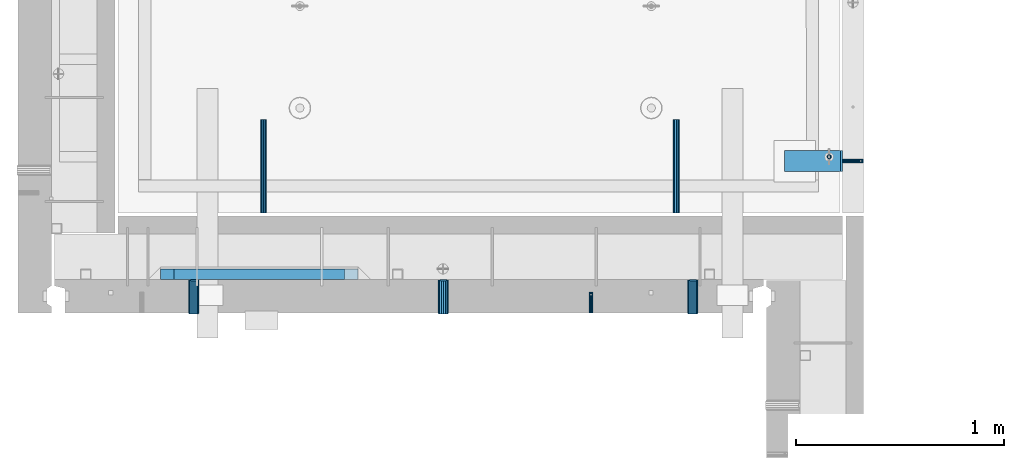
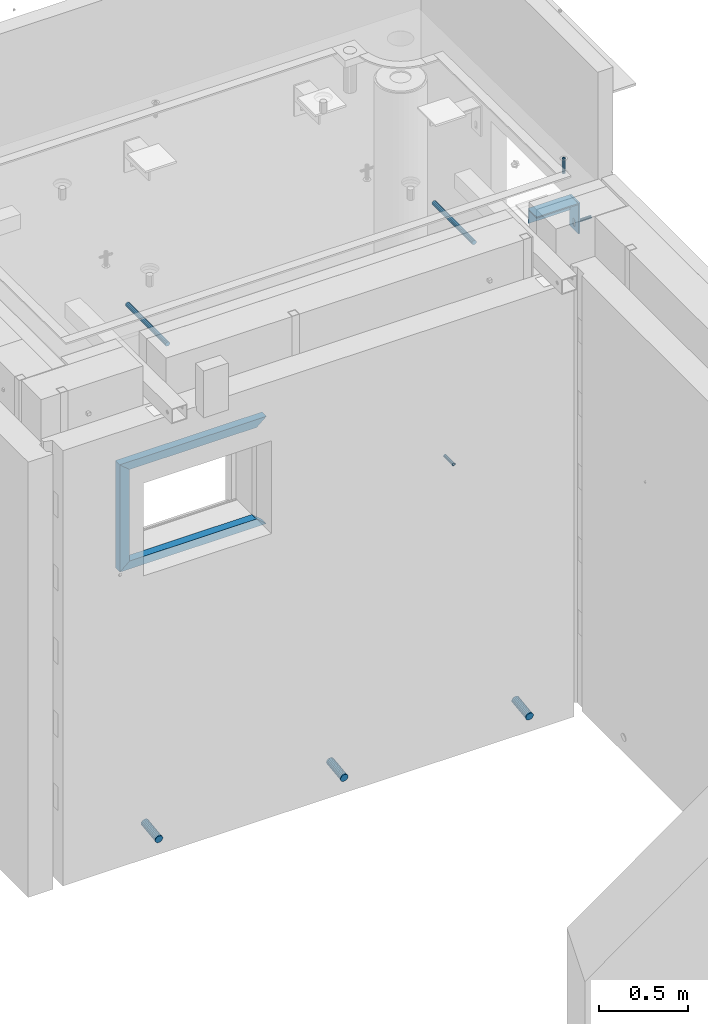
# One storey, part 113 of 264: 13 beams, 13 elements without a shape of their own.
"""IFC2X3 building model written with IfcOpenShell, lengths in millimetres."""

from ifc_helpers import new_model, si_unit, frame, origin_with_axes, place, context, subcontext, project, spatial, faceted_brep, material, type_object, element, aggregate, save


model = new_model("IFC2X3")

# Units and contexts
model_context = context("Model", 3, precision=1e-05, world=origin_with_axes())
body_context = subcontext(model_context, "Body", "Model", "MODEL_VIEW")
ifc_project = project(units=[si_unit("LENGTHUNIT", "METRE", prefix="MILLI"), si_unit("AREAUNIT", "SQUARE_METRE"), si_unit("VOLUMEUNIT", "CUBIC_METRE"), si_unit("MASSUNIT", "GRAM", prefix="KILO"), si_unit("TIMEUNIT", "SECOND"), si_unit("PLANEANGLEUNIT", "RADIAN"), si_unit("SOLIDANGLEUNIT", "STERADIAN"), si_unit("THERMODYNAMICTEMPERATUREUNIT", "DEGREE_CELSIUS"), si_unit("LUMINOUSINTENSITYUNIT", "LUMEN")], contexts=[model_context])

# Site, building, storey
site_placement = place(None, origin_with_axes())
site = spatial("IfcSite", under=ifc_project, at=site_placement, CompositionType="ELEMENT")
building_placement = place(site_placement, origin_with_axes())
building = spatial("IfcBuilding", under=site, at=building_placement, CompositionType="ELEMENT")
storey_placement = place(building_placement, origin_with_axes())
storey = spatial("IfcBuildingStorey", under=building, at=storey_placement, Name="K", CompositionType="ELEMENT", Elevation=0.0)

# Assemblies, beam
assembly_1_placement = place(storey_placement, origin_with_axes())
assembly_1 = element("IfcElementAssembly", 1, at=assembly_1_placement, inside=storey, AssemblyPlace="NOTDEFINED", PredefinedType="REINFORCEMENT_UNIT")
assembly_2_placement = place(assembly_1_placement, origin_with_axes())
assembly_2 = element("IfcElementAssembly", 2, at=assembly_2_placement, Name="Steel Assembly", AssemblyPlace="NOTDEFINED", PredefinedType="RIGID_FRAME")
aggregate(assembly_1, [assembly_2])
ifc_material_1 = material(Name="STEEL/1.4301")
beam_type_1 = type_object("IfcBeamType", PredefinedType="NOTDEFINED")
beam_1_placement = place(assembly_2_placement, frame((35264.9964028739, 21149.9972390075, 81285.0), z_axis=(0.0, -1.0, 0.0), x_axis=(1.0, 0.0, 0.0)))
beam_1 = element("IfcBeam", 3, at=beam_1_placement, type_object=beam_type_1, material=ifc_material_1, context=body_context, shape_type="Brep", body=[
    faceted_brep([(0.0, -8.49999999999272, -1.45519152283669e-11), (0.0, -7.36121593215648, 4.24999999998545), (100.000000000262, -7.36121593215648, 4.24999999998545), (100.000000000262, -8.49999999999272, -1.45519152283669e-11), (0.0, -4.24999999998545, 7.36121593216376), (100.000000000262, -4.24999999998545, 7.36121593216376), (0.0, 1.45519152283669e-11, 8.49999999998545), (100.000000000262, 1.45519152283669e-11, 8.49999999998545), (0.0, 4.25000000001455, 7.36121593216376), (100.000000000262, 4.25000000001455, 7.36121593216376), (0.0, 7.36121593217104, 4.24999999998545), (100.000000000262, 7.36121593217104, 4.24999999998545), (0.0, 8.50000000000728, 0.0), (100.000000000262, 8.50000000000728, 0.0), (0.0, 7.36121593217104, -4.25000000001455), (100.000000000262, 7.36121593217104, -4.25000000001455), (0.0, 4.25000000000728, -7.36121593219286), (100.000000000262, 4.25000000000728, -7.36121593219286), (0.0, 7.27595761418343e-12, -8.5), (100.000000000262, 7.27595761418343e-12, -8.5), (0.0, -4.24999999999272, -7.36121593217831), (100.000000000262, -4.24999999999272, -7.36121593217831), (0.0, -7.36121593215648, -4.25), (100.000000000262, -7.36121593215648, -4.25), (0.0, -10.4999999999927, -1.45519152283669e-11), (0.0, -9.09326673972828, -5.25000000001455), (100.000000000262, -9.09326673972828, -5.25000000001455), (100.000000000262, -10.4999999999927, -1.45519152283669e-11), (0.0, -5.24999999998545, -9.09326673974283), (100.000000000262, -5.24999999998545, -9.09326673974283), (0.0, 7.27595761418343e-12, -10.5), (100.000000000262, 7.27595761418343e-12, -10.5), (0.0, 5.25000000001455, -9.09326673975738), (100.000000000262, 5.25000000001455, -9.09326673975738), (0.0, 9.09326673975011, -5.25000000001455), (100.000000000262, 9.09326673975011, -5.25000000001455), (0.0, 10.5000000000073, -1.45519152283669e-11), (100.000000000262, 10.5000000000073, -1.45519152283669e-11), (0.0, 9.09326673975011, 5.25), (100.000000000262, 9.09326673975011, 5.25), (0.0, 5.25000000000728, 9.09326673972828), (100.000000000262, 5.25000000000728, 9.09326673972828), (0.0, 1.45519152283669e-11, 10.4999999999854), (100.000000000262, 1.45519152283669e-11, 10.4999999999854), (0.0, -5.24999999999272, 9.09326673972828), (100.000000000262, -5.24999999999272, 9.09326673972828), (0.0, -9.09326673972828, 5.24999999998545), (100.000000000262, -9.09326673972828, 5.24999999998545)], [[[0, 1, 2, 3]], [[1, 4, 5, 2]], [[4, 6, 7, 5]], [[6, 8, 9, 7]], [[8, 10, 11, 9]], [[10, 12, 13, 11]], [[12, 14, 15, 13]], [[14, 16, 17, 15]], [[16, 18, 19, 17]], [[18, 20, 21, 19]], [[20, 22, 23, 21]], [[22, 0, 3, 23]], [[24, 25, 26, 27]], [[25, 28, 29, 26]], [[28, 30, 31, 29]], [[30, 32, 33, 31]], [[32, 34, 35, 33]], [[34, 36, 37, 35]], [[36, 38, 39, 37]], [[38, 40, 41, 39]], [[40, 42, 43, 41]], [[42, 44, 45, 43]], [[44, 46, 47, 45]], [[46, 24, 27, 47]], [[29, 31, 33, 35, 37, 39, 41, 43, 45, 47, 27, 26], [5, 7, 9, 11, 13, 15, 17, 19, 21, 23, 3, 2]], [[46, 44, 42, 40, 38, 36, 34, 32, 30, 28, 25, 24], [22, 20, 18, 16, 14, 12, 10, 8, 6, 4, 1, 0]]]),
])
aggregate(assembly_2, [beam_1])

assembly_3_placement = place(storey_placement, origin_with_axes())
assembly_3 = element("IfcElementAssembly", 4, at=assembly_3_placement, inside=storey, AssemblyPlace="NOTDEFINED", PredefinedType="REINFORCEMENT_UNIT")
assembly_4_placement = place(assembly_3_placement, origin_with_axes())
assembly_4 = element("IfcElementAssembly", 5, at=assembly_4_placement, Name="Steel Assembly", AssemblyPlace="NOTDEFINED", PredefinedType="RIGID_FRAME")
ifc_material_2 = material(Name="STEEL/Steel_Undefined")
beam_2_placement = place(assembly_4_placement, frame((34054.9971684879, 20420.0, 80490.0), z_axis=(1.0, 0.0, 0.0), x_axis=(0.0, 1.0, 0.0)))
beam_2 = element("IfcBeam", 6, at=beam_2_placement, type_object=beam_type_1, material=ifc_material_2, Name="M16", context=body_context, shape_type="Brep", body=[
    faceted_brep([(0.0, -8.49999999999272, -1.45519152283669e-11), (0.0, -7.36121593215648, 4.24999999998545), (100.000000000262, -7.36121593215648, 4.24999999998545), (100.000000000262, -8.49999999999272, -1.45519152283669e-11), (0.0, -4.24999999998545, 7.36121593216376), (100.000000000262, -4.24999999998545, 7.36121593216376), (0.0, 1.45519152283669e-11, 8.49999999998545), (100.000000000262, 1.45519152283669e-11, 8.49999999998545), (0.0, 4.25000000001455, 7.36121593216376), (100.000000000262, 4.25000000001455, 7.36121593216376), (0.0, 7.36121593217104, 4.24999999998545), (100.000000000262, 7.36121593217104, 4.24999999998545), (0.0, 8.50000000000728, 0.0), (100.000000000262, 8.50000000000728, 0.0), (0.0, 7.36121593217104, -4.25000000001455), (100.000000000262, 7.36121593217104, -4.25000000001455), (0.0, 4.25000000000728, -7.36121593219286), (100.000000000262, 4.25000000000728, -7.36121593219286), (0.0, 7.27595761418343e-12, -8.5), (100.000000000262, 7.27595761418343e-12, -8.5), (0.0, -4.24999999999272, -7.36121593217831), (100.000000000262, -4.24999999999272, -7.36121593217831), (0.0, -7.36121593215648, -4.25), (100.000000000262, -7.36121593215648, -4.25), (0.0, -10.4999999999927, -1.45519152283669e-11), (0.0, -9.09326673972828, -5.25000000001455), (100.000000000262, -9.09326673972828, -5.25000000001455), (100.000000000262, -10.4999999999927, -1.45519152283669e-11), (0.0, -5.24999999998545, -9.09326673974283), (100.000000000262, -5.24999999998545, -9.09326673974283), (0.0, 7.27595761418343e-12, -10.5), (100.000000000262, 7.27595761418343e-12, -10.5), (0.0, 5.25000000001455, -9.09326673975738), (100.000000000262, 5.25000000001455, -9.09326673975738), (0.0, 9.09326673975011, -5.25000000001455), (100.000000000262, 9.09326673975011, -5.25000000001455), (0.0, 10.5000000000073, -1.45519152283669e-11), (100.000000000262, 10.5000000000073, -1.45519152283669e-11), (0.0, 9.09326673975011, 5.25), (100.000000000262, 9.09326673975011, 5.25), (0.0, 5.25000000000728, 9.09326673972828), (100.000000000262, 5.25000000000728, 9.09326673972828), (0.0, 1.45519152283669e-11, 10.4999999999854), (100.000000000262, 1.45519152283669e-11, 10.4999999999854), (0.0, -5.24999999999272, 9.09326673972828), (100.000000000262, -5.24999999999272, 9.09326673972828), (0.0, -9.09326673972828, 5.24999999998545), (100.000000000262, -9.09326673972828, 5.24999999998545)], [[[0, 1, 2, 3]], [[1, 4, 5, 2]], [[4, 6, 7, 5]], [[6, 8, 9, 7]], [[8, 10, 11, 9]], [[10, 12, 13, 11]], [[12, 14, 15, 13]], [[14, 16, 17, 15]], [[16, 18, 19, 17]], [[18, 20, 21, 19]], [[20, 22, 23, 21]], [[22, 0, 3, 23]], [[24, 25, 26, 27]], [[25, 28, 29, 26]], [[28, 30, 31, 29]], [[30, 32, 33, 31]], [[32, 34, 35, 33]], [[34, 36, 37, 35]], [[36, 38, 39, 37]], [[38, 40, 41, 39]], [[40, 42, 43, 41]], [[42, 44, 45, 43]], [[44, 46, 47, 45]], [[46, 24, 27, 47]], [[29, 31, 33, 35, 37, 39, 41, 43, 45, 47, 27, 26], [5, 7, 9, 11, 13, 15, 17, 19, 21, 23, 3, 2]], [[46, 44, 42, 40, 38, 36, 34, 32, 30, 28, 25, 24], [22, 20, 18, 16, 14, 12, 10, 8, 6, 4, 1, 0]]]),
])
aggregate(assembly_4, [beam_2])

# Assemblies, beams
assembly_5_placement = place(storey_placement, origin_with_axes())
assembly_5 = element("IfcElementAssembly", 7, at=assembly_5_placement, inside=storey, AssemblyPlace="NOTDEFINED", PredefinedType="REINFORCEMENT_UNIT")
assembly_6_placement = place(assembly_5_placement, origin_with_axes())
assembly_6 = element("IfcElementAssembly", 8, at=assembly_6_placement, Name="Steel Assembly", AssemblyPlace="NOTDEFINED", PredefinedType="RIGID_FRAME")
beam_type_2 = type_object("IfcBeamType", PredefinedType="NOTDEFINED")
beam_3_placement = place(assembly_6_placement, frame((35199.9998195517, 21170.0002421332, 81731.0000000089), z_axis=(0.999999999984675, 3.40399999908427e-06, -4.36599999368485e-06), x_axis=(-4.36599999292741e-06, 0.0, -0.999999999990469)))
beam_3 = element("IfcBeam", 9, at=beam_3_placement, type_object=beam_type_2, material=ifc_material_1, context=body_context, shape_type="Brep", body=[
    faceted_brep([(0.0, -8.0, 0.0), (0.0, -6.92820323027263, 4.0), (100.000000000029, -6.92820323027263, 4.0), (100.000000000029, -7.99999999999636, 0.0), (0.0, -4.0, 6.92820323027627), (100.000000000029, -4.0, 6.92820323027536), (0.0, 0.0, 8.0), (100.000000000029, 3.63797880709171e-12, 8.0), (0.0, 4.0, 6.92820323027627), (100.000000000029, 4.0, 6.92820323027536), (0.0, 6.92820323027263, 4.0), (100.000000000029, 6.92820323027627, 3.99999999999909), (0.0, 8.0, 0.0), (100.000000000029, 8.0, 0.0), (0.0, 6.92820323027263, -4.0), (100.000000000029, 6.92820323027627, -4.00000000000091), (0.0, 4.0, -6.92820323027627), (100.000000000029, 4.00000000000364, -6.92820323027536), (0.0, 0.0, -8.0), (100.000000000029, 3.63797880709171e-12, -8.00000000000091), (0.0, -4.0, -6.92820323027627), (100.000000000029, -3.99999999999636, -6.92820323027627), (0.0, -6.92820323027263, -4.0), (100.000000000029, -6.92820323027263, -4.0), (0.0, -10.4999999999927, -1.45519152283669e-11), (0.0, -9.09326673972828, -5.25000000001455), (100.000000000262, -9.09326673972828, -5.25000000001455), (100.000000000262, -10.4999999999927, -1.45519152283669e-11), (0.0, -5.24999999998545, -9.09326673974283), (100.000000000262, -5.24999999998545, -9.09326673974283), (0.0, 7.27595761418343e-12, -10.5), (100.000000000262, 7.27595761418343e-12, -10.5), (0.0, 5.25000000001455, -9.09326673975738), (100.000000000262, 5.25000000001455, -9.09326673975738), (0.0, 9.09326673975011, -5.25000000001455), (100.000000000262, 9.09326673975011, -5.25000000001455), (0.0, 10.5000000000073, -1.45519152283669e-11), (100.000000000262, 10.5000000000073, -1.45519152283669e-11), (0.0, 9.09326673975011, 5.25), (100.000000000262, 9.09326673975011, 5.25), (0.0, 5.25000000000728, 9.09326673972828), (100.000000000262, 5.25000000000728, 9.09326673972828), (0.0, 1.45519152283669e-11, 10.4999999999854), (100.000000000262, 1.45519152283669e-11, 10.4999999999854), (0.0, -5.24999999999272, 9.09326673972828), (100.000000000262, -5.24999999999272, 9.09326673972828), (0.0, -9.09326673972828, 5.24999999998545), (100.000000000262, -9.09326673972828, 5.24999999998545)], [[[0, 1, 2, 3]], [[1, 4, 5, 2]], [[4, 6, 7, 5]], [[6, 8, 9, 7]], [[8, 10, 11, 9]], [[10, 12, 13, 11]], [[12, 14, 15, 13]], [[14, 16, 17, 15]], [[16, 18, 19, 17]], [[18, 20, 21, 19]], [[20, 22, 23, 21]], [[22, 0, 3, 23]], [[24, 25, 26, 27]], [[25, 28, 29, 26]], [[28, 30, 31, 29]], [[30, 32, 33, 31]], [[32, 34, 35, 33]], [[34, 36, 37, 35]], [[36, 38, 39, 37]], [[38, 40, 41, 39]], [[40, 42, 43, 41]], [[42, 44, 45, 43]], [[44, 46, 47, 45]], [[46, 24, 27, 47]], [[29, 31, 33, 35, 37, 39, 41, 43, 45, 47, 27, 26], [5, 7, 9, 11, 13, 15, 17, 19, 21, 23, 3, 2]], [[46, 44, 42, 40, 38, 36, 34, 32, 30, 28, 25, 24], [22, 20, 18, 16, 14, 12, 10, 8, 6, 4, 1, 0]]]),
])
aggregate(assembly_6, [beam_3])
assembly_7_placement = place(assembly_5_placement, origin_with_axes())
assembly_7 = element("IfcElementAssembly", 10, at=assembly_7_placement, Name="Steel Assembly", AssemblyPlace="NOTDEFINED", PredefinedType="RIGID_FRAME")
ifc_material_3 = material(Name="STEEL/S235JR")
beam_type_3 = type_object("IfcBeamType", Name="D30", PredefinedType="NOTDEFINED")
beam_4_placement = place(assembly_7_placement, frame((32479.9998567563, 20900.0253394533, 81575.0), z_axis=(0.0, 0.0, 1.0), x_axis=(0.0, 1.0, 0.0)))
beam_4 = element("IfcBeam", 11, at=beam_4_placement, type_object=beam_type_3, material=ifc_material_3, Name="Rd30", ObjectType="D30", context=body_context, shape_type="Brep", body=[
    faceted_brep([(0.0, -15.0, 0.0), (0.0, -12.9903810567666, -7.5), (450.0, -12.9903810567666, -7.5), (450.0, -15.0, 0.0), (0.0, -7.5, -12.9903810567666), (450.0, -7.5, -12.990381056763), (0.0, 0.0, -15.0), (450.0, 0.0, -15.0), (0.0, 7.5, -12.9903810567666), (450.0, 7.5, -12.990381056763), (0.0, 12.9903810567666, -7.5), (450.0, 12.9903810567666, -7.5), (0.0, 15.0, 0.0), (450.0, 15.0, 0.0), (0.0, 12.9903810567666, 7.5), (450.0, 12.9903810567666, 7.5), (0.0, 7.5, 12.9903810567666), (450.0, 7.5, 12.990381056763), (0.0, 0.0, 15.0), (450.0, 0.0, 15.0), (0.0, -7.5, 12.9903810567666), (450.0, -7.5, 12.990381056763), (0.0, -12.9903810567666, 7.5), (450.0, -12.9903810567666, 7.5)], [[[0, 1, 2, 3]], [[1, 4, 5, 2]], [[4, 6, 7, 5]], [[6, 8, 9, 7]], [[8, 10, 11, 9]], [[10, 12, 13, 11]], [[12, 14, 15, 13]], [[14, 16, 17, 15]], [[16, 18, 19, 17]], [[18, 20, 21, 19]], [[20, 22, 23, 21]], [[22, 0, 3, 23]], [[5, 7, 9, 11, 13, 15, 17, 19, 21, 23, 3, 2]], [[22, 20, 18, 16, 14, 12, 10, 8, 6, 4, 1, 0]]]),
])
aggregate(assembly_7, [beam_4])
assembly_8_placement = place(assembly_5_placement, origin_with_axes())
assembly_8 = element("IfcElementAssembly", 12, at=assembly_8_placement, Name="Steel Assembly", AssemblyPlace="NOTDEFINED", PredefinedType="RIGID_FRAME")
aggregate(assembly_5, [assembly_6, assembly_7, assembly_8])
beam_5_placement = place(assembly_8_placement, frame((34464.9998570066, 20900.0152136098, 81575.0), z_axis=(0.0, 0.0, 1.0), x_axis=(0.0, 1.0, 0.0)))
beam_5 = element("IfcBeam", 13, at=beam_5_placement, type_object=beam_type_3, material=ifc_material_3, Name="Rd30", ObjectType="D30", context=body_context, shape_type="Brep", body=[
    faceted_brep([(0.0, -15.0, 0.0), (0.0, -12.9903810567666, -7.5), (450.0, -12.9903810567666, -7.5), (450.0, -15.0, 0.0), (0.0, -7.5, -12.9903810567666), (450.0, -7.5, -12.990381056763), (0.0, 0.0, -15.0), (450.0, 0.0, -15.0), (0.0, 7.5, -12.9903810567666), (450.0, 7.5, -12.990381056763), (0.0, 12.9903810567666, -7.5), (450.0, 12.9903810567666, -7.5), (0.0, 15.0, 0.0), (450.0, 15.0, 0.0), (0.0, 12.9903810567666, 7.5), (450.0, 12.9903810567666, 7.5), (0.0, 7.5, 12.9903810567666), (450.0, 7.5, 12.990381056763), (0.0, 0.0, 15.0), (450.0, 0.0, 15.0), (0.0, -7.5, 12.9903810567666), (450.0, -7.5, 12.990381056763), (0.0, -12.9903810567666, 7.5), (450.0, -12.9903810567666, 7.5)], [[[0, 1, 2, 3]], [[1, 4, 5, 2]], [[4, 6, 7, 5]], [[6, 8, 9, 7]], [[8, 10, 11, 9]], [[10, 12, 13, 11]], [[12, 14, 15, 13]], [[14, 16, 17, 15]], [[16, 18, 19, 17]], [[18, 20, 21, 19]], [[20, 22, 23, 21]], [[22, 0, 3, 23]], [[5, 7, 9, 11, 13, 15, 17, 19, 21, 23, 3, 2]], [[22, 20, 18, 16, 14, 12, 10, 8, 6, 4, 1, 0]]]),
])
aggregate(assembly_8, [beam_5])

# Assembly, beam
assembly_9_placement = place(assembly_3_placement, origin_with_axes())
assembly_9 = element("IfcElementAssembly", 14, at=assembly_9_placement, Name="Steel Assembly", AssemblyPlace="NOTDEFINED", PredefinedType="NOTDEFINED")
ifc_material_4 = material()
beam_type_4 = type_object("IfcBeamType", Name="D50", PredefinedType="NOTDEFINED")
beam_6_placement = place(assembly_9_placement, frame((34544.9952566975, 20576.8991316354, 78614.8069469184), z_axis=(-1.0, 3.00000001838171e-08, 0.0), x_axis=(4.58000007625869e-07, -0.992277876667409, -0.124034734958437)))
beam_6 = element("IfcBeam", 15, at=beam_6_placement, type_object=beam_type_4, material=ifc_material_4, ObjectType="D50", context=body_context, shape_type="Brep", body=[
    faceted_brep([(0.0, -25.0, 0.0), (-3.63797880709171e-12, -23.0969883127837, -9.56708580912891), (161.245154974295, -23.0969883127982, -9.56708580912891), (161.245154970162, -25.0000000000146, -3.63797880709171e-12), (-3.63797880709171e-12, -17.6776695296576, -17.6776695296649), (161.245154977802, -17.6776695296721, -17.6776695296576), (-1.09139364212751e-11, -9.56708580913255, -23.0969883127837), (161.245154980144, -9.56708580913255, -23.0969883127837), (-1.09139364212751e-11, 0.0, -25.0), (161.245154980967, -1.45519152283669e-11, -25.0), (-1.09139364212751e-11, 9.56708580913255, -23.0969883127837), (161.245154980144, 9.567085809118, -23.09698831278), (-3.63797880709171e-12, 17.6776695296576, -17.6776695296649), (161.245154977802, 17.6776695296576, -17.6776695296612), (-3.63797880709171e-12, 23.0969883127837, -9.56708580912891), (161.245154974295, 23.0969883127691, -9.56708580912891), (0.0, 25.0, 0.0), (161.245154970158, 25.0, 3.63797880709171e-12), (7.27595761418343e-12, 23.0969883127837, 9.56708580912891), (161.245154966022, 23.0969883127691, 9.56708580912891), (7.27595761418343e-12, 17.6776695296576, 17.6776695296649), (161.245154962515, 17.677669529643, 17.6776695296649), (1.45519152283669e-11, 9.56708580913255, 23.0969883127837), (161.245154960172, 9.567085809118, 23.09698831278), (1.09139364212751e-11, 0.0, 25.0), (161.24515495935, -1.45519152283669e-11, 24.9999999999964), (1.45519152283669e-11, -9.56708580913255, 23.0969883127837), (161.245154960168, -9.56708580913255, 23.09698831278), (7.27595761418343e-12, -17.6776695296576, 17.6776695296649), (161.245154962515, -17.6776695296721, 17.6776695296685), (7.27595761418343e-12, -23.0969883127837, 9.56708580912891), (161.245154966022, -23.0969883127982, 9.56708580912527)], [[[0, 1, 2, 3]], [[1, 4, 5, 2]], [[4, 6, 7, 5]], [[6, 8, 9, 7]], [[8, 10, 11, 9]], [[10, 12, 13, 11]], [[12, 14, 15, 13]], [[14, 16, 17, 15]], [[16, 18, 19, 17]], [[18, 20, 21, 19]], [[20, 22, 23, 21]], [[22, 24, 25, 23]], [[24, 26, 27, 25]], [[26, 28, 29, 27]], [[28, 30, 31, 29]], [[30, 0, 3, 31]], [[5, 7, 9, 11, 13, 15, 17, 19, 21, 23, 25, 27, 29, 31, 3, 2]], [[30, 28, 26, 24, 22, 20, 18, 16, 14, 12, 10, 8, 6, 4, 1, 0]]]),
])
aggregate(assembly_9, [beam_6])

assembly_10_placement = place(assembly_3_placement, origin_with_axes())
assembly_10 = element("IfcElementAssembly", 16, at=assembly_10_placement, Name="Steel Assembly", AssemblyPlace="NOTDEFINED", PredefinedType="NOTDEFINED")
beam_7_placement = place(assembly_10_placement, frame((33344.9952566975, 20576.8991316354, 78614.8069469184), z_axis=(-1.0, 3.00000001838171e-08, 0.0), x_axis=(4.58000007625869e-07, -0.992277876667409, -0.124034734958437)))
beam_7 = element("IfcBeam", 17, at=beam_7_placement, type_object=beam_type_4, material=ifc_material_4, ObjectType="D50", context=body_context, shape_type="Brep", body=[
    faceted_brep([(0.0, -25.0, 0.0), (-3.63797880709171e-12, -23.0969883127837, -9.56708580912891), (161.245154974295, -23.0969883127982, -9.56708580912891), (161.245154970162, -25.0000000000146, -3.63797880709171e-12), (-3.63797880709171e-12, -17.6776695296576, -17.6776695296649), (161.245154977802, -17.6776695296721, -17.6776695296576), (-1.09139364212751e-11, -9.56708580913255, -23.0969883127837), (161.245154980144, -9.56708580913255, -23.0969883127837), (-1.09139364212751e-11, 0.0, -25.0), (161.245154980967, -1.45519152283669e-11, -25.0), (-1.09139364212751e-11, 9.56708580913255, -23.0969883127837), (161.245154980144, 9.567085809118, -23.09698831278), (-3.63797880709171e-12, 17.6776695296576, -17.6776695296649), (161.245154977802, 17.6776695296576, -17.6776695296612), (-3.63797880709171e-12, 23.0969883127837, -9.56708580912891), (161.245154974295, 23.0969883127691, -9.56708580912891), (0.0, 25.0, 0.0), (161.245154970158, 25.0, 3.63797880709171e-12), (7.27595761418343e-12, 23.0969883127837, 9.56708580912891), (161.245154966022, 23.0969883127691, 9.56708580912891), (7.27595761418343e-12, 17.6776695296576, 17.6776695296649), (161.245154962515, 17.677669529643, 17.6776695296649), (1.45519152283669e-11, 9.56708580913255, 23.0969883127837), (161.245154960172, 9.567085809118, 23.09698831278), (1.09139364212751e-11, 0.0, 25.0), (161.24515495935, -1.45519152283669e-11, 24.9999999999964), (1.45519152283669e-11, -9.56708580913255, 23.0969883127837), (161.245154960168, -9.56708580913255, 23.09698831278), (7.27595761418343e-12, -17.6776695296576, 17.6776695296649), (161.245154962515, -17.6776695296721, 17.6776695296685), (7.27595761418343e-12, -23.0969883127837, 9.56708580912891), (161.245154966022, -23.0969883127982, 9.56708580912527)], [[[0, 1, 2, 3]], [[1, 4, 5, 2]], [[4, 6, 7, 5]], [[6, 8, 9, 7]], [[8, 10, 11, 9]], [[10, 12, 13, 11]], [[12, 14, 15, 13]], [[14, 16, 17, 15]], [[16, 18, 19, 17]], [[18, 20, 21, 19]], [[20, 22, 23, 21]], [[22, 24, 25, 23]], [[24, 26, 27, 25]], [[26, 28, 29, 27]], [[28, 30, 31, 29]], [[30, 0, 3, 31]], [[5, 7, 9, 11, 13, 15, 17, 19, 21, 23, 25, 27, 29, 31, 3, 2]], [[30, 28, 26, 24, 22, 20, 18, 16, 14, 12, 10, 8, 6, 4, 1, 0]]]),
])
aggregate(assembly_10, [beam_7])

assembly_11_placement = place(assembly_3_placement, origin_with_axes())
assembly_11 = element("IfcElementAssembly", 18, at=assembly_11_placement, Name="Steel Assembly", AssemblyPlace="NOTDEFINED", PredefinedType="NOTDEFINED")
beam_8_placement = place(assembly_11_placement, frame((32144.9952566975, 20576.8991316354, 78614.8069469184), z_axis=(-1.0, 3.00000001838171e-08, 0.0), x_axis=(4.58000007625869e-07, -0.992277876667409, -0.124034734958437)))
beam_8 = element("IfcBeam", 19, at=beam_8_placement, type_object=beam_type_4, material=ifc_material_4, ObjectType="D50", context=body_context, shape_type="Brep", body=[
    faceted_brep([(0.0, -25.0, 0.0), (-3.63797880709171e-12, -23.0969883127837, -9.56708580912891), (161.245154974295, -23.0969883127982, -9.56708580912891), (161.245154970162, -25.0000000000146, -3.63797880709171e-12), (-3.63797880709171e-12, -17.6776695296576, -17.6776695296649), (161.245154977802, -17.6776695296721, -17.6776695296576), (-1.09139364212751e-11, -9.56708580913255, -23.0969883127837), (161.245154980144, -9.56708580913255, -23.0969883127837), (-1.09139364212751e-11, 0.0, -25.0), (161.245154980967, -1.45519152283669e-11, -25.0), (-1.09139364212751e-11, 9.56708580913255, -23.0969883127837), (161.245154980144, 9.567085809118, -23.09698831278), (-3.63797880709171e-12, 17.6776695296576, -17.6776695296649), (161.245154977802, 17.6776695296576, -17.6776695296612), (-3.63797880709171e-12, 23.0969883127837, -9.56708580912891), (161.245154974295, 23.0969883127691, -9.56708580912891), (0.0, 25.0, 0.0), (161.245154970158, 25.0, 3.63797880709171e-12), (7.27595761418343e-12, 23.0969883127837, 9.56708580912891), (161.245154966022, 23.0969883127691, 9.56708580912891), (7.27595761418343e-12, 17.6776695296576, 17.6776695296649), (161.245154962515, 17.677669529643, 17.6776695296649), (1.45519152283669e-11, 9.56708580913255, 23.0969883127837), (161.245154960172, 9.567085809118, 23.09698831278), (1.09139364212751e-11, 0.0, 25.0), (161.24515495935, -1.45519152283669e-11, 24.9999999999964), (1.45519152283669e-11, -9.56708580913255, 23.0969883127837), (161.245154960168, -9.56708580913255, 23.09698831278), (7.27595761418343e-12, -17.6776695296576, 17.6776695296649), (161.245154962515, -17.6776695296721, 17.6776695296685), (7.27595761418343e-12, -23.0969883127837, 9.56708580912891), (161.245154966022, -23.0969883127982, 9.56708580912527)], [[[0, 1, 2, 3]], [[1, 4, 5, 2]], [[4, 6, 7, 5]], [[6, 8, 9, 7]], [[8, 10, 11, 9]], [[10, 12, 13, 11]], [[12, 14, 15, 13]], [[14, 16, 17, 15]], [[16, 18, 19, 17]], [[18, 20, 21, 19]], [[20, 22, 23, 21]], [[22, 24, 25, 23]], [[24, 26, 27, 25]], [[26, 28, 29, 27]], [[28, 30, 31, 29]], [[30, 0, 3, 31]], [[5, 7, 9, 11, 13, 15, 17, 19, 21, 23, 25, 27, 29, 31, 3, 2]], [[30, 28, 26, 24, 22, 20, 18, 16, 14, 12, 10, 8, 6, 4, 1, 0]]]),
])
aggregate(assembly_11, [beam_8])

assembly_12_placement = place(storey_placement, origin_with_axes())
assembly_12 = element("IfcElementAssembly", 20, at=assembly_12_placement, inside=storey, Name="Steel Assembly", AssemblyPlace="NOTDEFINED", PredefinedType="RIGID_FRAME")
beam_type_5 = type_object("IfcBeamType", PredefinedType="NOTDEFINED")
beam_9_placement = place(assembly_12_placement, frame((35260.0002194488, 21200.0035213377, 81340.0), z_axis=(0.0, 0.0, -1.0), x_axis=(0.0, -1.0, 0.0)))
beam_9 = element("IfcBeam", 21, at=beam_9_placement, type_object=beam_type_5, material=ifc_material_1, context=body_context, shape_type="Brep", body=[
    faceted_brep([(39.0000000000073, -5.0, 72.0000000000146), (39.0000000000073, 5.0, 72.0000000000146), (39.6089637399164, 5.0, 75.0614674589306), (39.6089637399164, -5.0, 75.0614674589306), (41.3431457505139, 5.0, 77.6568542495079), (41.3431457505139, -5.0, 77.6568542495079), (43.9385325410876, 5.0, 79.3910362601018), (43.9385325410876, -5.0, 79.3910362601018), (47.0000000000073, 5.0, 80.0000000000146), (47.0000000000073, -5.0, 80.0000000000146), (53.0000000000073, 5.0, 80.0000000000146), (53.0000000000073, -5.0, 80.0000000000146), (56.0614674589269, 5.0, 79.3910362601018), (56.0614674589269, -5.0, 79.3910362601018), (58.6568542495006, 5.0, 77.6568542495079), (58.6568542495006, -5.0, 77.6568542495079), (60.3910362600982, 5.0, 75.0614674589306), (60.3910362600982, -5.0, 75.0614674589306), (61.0000000000073, 5.0, 72.0000000000146), (61.0000000000073, -5.0, 72.0000000000146), (61.0000000000036, 5.0, 38.0000000000146), (61.0000000000036, -5.0, 38.0000000000146), (60.3910362600946, 5.0, 34.9385325410985), (60.3910362600946, -5.0, 34.9385325410985), (58.656854249497, 5.0, 32.3431457505212), (58.656854249497, -5.0, 32.3431457505212), (56.0614674589233, 5.0, 30.6089637399273), (56.0614674589233, -5.0, 30.6089637399273), (53.0000000000036, 5.0, 30.0000000000146), (53.0000000000036, -5.0, 30.0000000000146), (47.0000000000073, 5.0, 30.0000000000146), (47.0000000000073, -5.0, 30.0000000000146), (43.9385325410876, 5.0, 30.6089637399273), (43.9385325410876, -5.0, 30.6089637399273), (41.3431457505139, 5.0, 32.3431457505212), (41.3431457505139, -5.0, 32.3431457505212), (39.6089637399164, 5.0, 34.9385325410985), (39.6089637399164, -5.0, 34.9385325410985), (39.0000000000073, 5.0, 38.0000000000146), (39.0000000000073, -5.0, 38.0000000000146), (0.0, -5.0, 105.0), (0.0, -5.0, -105.0), (100.0, -5.0, -105.0), (100.0, -5.0, 105.0), (0.0, 5.0, 105.0), (100.0, 5.0, 105.0), (0.0, 5.0, -105.0), (100.0, 5.0, -105.0)], [[[0, 1, 2, 3]], [[3, 2, 4, 5]], [[5, 4, 6, 7]], [[7, 6, 8, 9]], [[9, 8, 10, 11]], [[11, 10, 12, 13]], [[13, 12, 14, 15]], [[15, 14, 16, 17]], [[17, 16, 18, 19]], [[19, 18, 20, 21]], [[21, 20, 22, 23]], [[23, 22, 24, 25]], [[25, 24, 26, 27]], [[27, 26, 28, 29]], [[29, 28, 30, 31]], [[31, 30, 32, 33]], [[33, 32, 34, 35]], [[35, 34, 36, 37]], [[37, 36, 38, 39]], [[39, 38, 1, 0]], [[40, 41, 42, 43], [3, 5, 7, 9, 11, 13, 15, 17, 19, 21, 23, 25, 27, 29, 31, 33, 35, 37, 39, 0]], [[44, 40, 43, 45]], [[41, 40, 44, 46]], [[41, 46, 47, 42]], [[43, 42, 47, 45]], [[46, 44, 45, 47], [34, 32, 30, 28, 26, 24, 22, 20, 18, 16, 14, 12, 10, 8, 6, 4, 2, 1, 38, 36]]]),
])
aggregate(assembly_12, [beam_9])

assembly_13_placement = place(storey_placement, origin_with_axes())
assembly_13 = element("IfcElementAssembly", 22, at=assembly_13_placement, inside=storey, Name="Steel Assembly", AssemblyPlace="NOTDEFINED", PredefinedType="RIGID_FRAME")
beam_type_6 = type_object("IfcBeamType", PredefinedType="NOTDEFINED")
beam_10_placement = place(assembly_13_placement, frame((34985.0002194488, 21150.0035213377, 81395.0), z_axis=(0.0, -1.0, 0.0), x_axis=(1.0, 0.0, 0.0)))
beam_10 = element("IfcBeam", 23, at=beam_10_placement, type_object=beam_type_6, material=ifc_material_1, Name="L", context=body_context, shape_type="Brep", body=[
    faceted_brep([(1.81898940354586e-12, 49.9999999999991, -50.0), (1.81898940354586e-12, 49.9999999999991, 50.0), (270.0, 50.0, 50.0), (270.0, 50.0, -50.0), (0.0, 42.0, 50.0), (270.0, 42.0, 50.0), (0.0, 42.0, -42.0), (270.0, 42.0, -42.0), (0.0, -50.0, -42.0), (270.0, -50.0, -42.0), (1.81898940354586e-12, -50.0000000000009, -50.0), (270.0, -50.0, -50.0)], [[[0, 1, 2, 3]], [[1, 4, 5, 2]], [[4, 6, 7, 5]], [[6, 8, 9, 7]], [[8, 10, 11, 9]], [[10, 0, 3, 11]], [[5, 7, 9, 11, 3, 2]], [[10, 8, 6, 4, 1, 0]]]),
])
aggregate(assembly_13, [beam_10])

# Beam
ifc_material_5 = material(Name="CONCRETE/C25/30")
beam_type_7 = type_object("IfcBeamType", PredefinedType="NOTDEFINED")
beam_11_placement = place(assembly_3_placement, frame((32935.0013718009, 20605.0, 81085.0), z_axis=(0.0, 0.0, -1.0), x_axis=(-1.0, 3.00000001838171e-08, 0.0)))
beam_11 = element("IfcBeam", 24, at=beam_11_placement, type_object=beam_type_7, material=ifc_material_5, context=body_context, shape_type="Brep", body=[
    faceted_brep([(64.3273760821321, -25.0, 25.1377509154554), (65.6787274334856, 25.0, 26.2960520734923), (0.0, 25.0, -30.0), (0.0, -25.0, -30.0), (64.3273760821321, -25.0, 24.3243243243342), (65.6787274334856, 25.0, 25.6756756756804), (885.678727433486, -25.0, 24.3243243243342), (884.327376082136, 25.0, 25.6756756756804), (884.327376082136, 25.0, 26.2934362810629), (950.003051757813, 25.0, -30.0), (950.003051757813, -25.0, -30.0), (885.678727433486, -25.0, 25.135135123026)], [[[0, 1, 2, 3]], [[4, 5, 1, 0]], [[6, 7, 5, 4]], [[2, 1, 5, 7, 8, 9]], [[3, 2, 9, 10]], [[6, 4, 0, 3, 10, 11]], [[7, 6, 11, 8]], [[10, 9, 8, 11]]]),
])

beam_12_placement = place(assembly_3_placement, frame((31984.9983200431, 20605.0, 80410.0), z_axis=(0.0, 0.0, 1.0), x_axis=(1.0, 0.0, 0.0)))
beam_12 = element("IfcBeam", 25, at=beam_12_placement, type_object=beam_type_7, material=ifc_material_5, context=body_context, shape_type="Brep", body=[
    faceted_brep([(885.67567567568, -25.0, 25.1377509154408), (950.003051757813, -25.0, -30.0), (950.003051757813, 25.0, -30.0), (884.324324324327, 25.0, 26.2960520734923), (884.324324324327, 25.0, 25.6756756756804), (885.67567567568, -25.0, 24.3243243243342), (65.6756756756768, 25.0, 25.6756756756804), (64.3243243243269, -25.0, 24.3243243243342), (65.6756756756768, 25.0, 26.2934362810774), (64.3243243243269, -25.0, 25.135135123026), (0.0, -25.0, -30.0), (0.0, 25.0, -30.0)], [[[0, 1, 2, 3]], [[4, 5, 0, 3]], [[5, 4, 6, 7]], [[7, 6, 8, 9]], [[1, 0, 5, 7, 9, 10]], [[10, 11, 2, 1]], [[6, 4, 3, 2, 11, 8]], [[10, 9, 8, 11]]]),
])

beam_type_8 = type_object("IfcBeamType", PredefinedType="NOTDEFINED")
beam_13_placement = place(assembly_3_placement, frame((32019.9983200431, 20605.0, 81115.0), z_axis=(1.0, 0.0, 0.0), x_axis=(0.0, 0.0, -1.0)))
beam_13 = element("IfcBeam", 26, at=beam_13_placement, type_object=beam_type_8, material=ifc_material_5, context=body_context, shape_type="Brep", body=[
    faceted_brep([(0.0, -25.0, -35.0), (55.135135123026, -25.0, 29.3243243243269), (56.2934362810629, 25.0, 30.6756756756768), (0.0, 25.0, -35.0), (678.706563718923, 25.0, 30.6756756756768), (735.0, 25.0, -35.0), (735.0, -25.0, -35.0), (679.864864876974, -25.0, 29.3243243243269)], [[[0, 1, 2, 3]], [[3, 2, 4, 5]], [[5, 6, 0, 3]], [[1, 0, 6, 7]], [[2, 1, 7, 4]], [[6, 5, 4, 7]]]),
])

aggregate(assembly_3, [assembly_4, beam_11, beam_13, beam_12, assembly_9, assembly_10, assembly_11])

save(model, "model.ifc")
